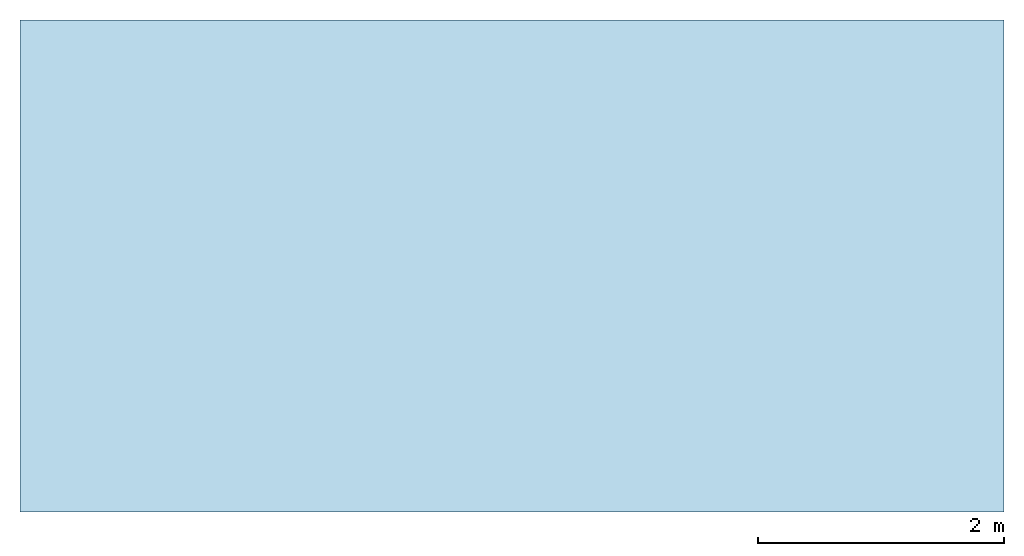
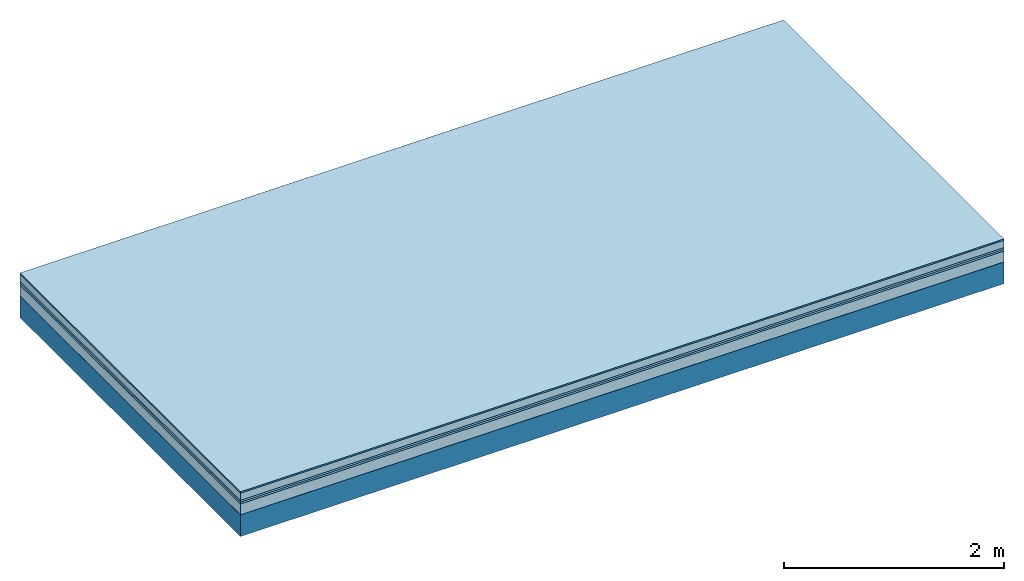
# One storey: 6 plates, 1 member, 1 element without a shape of its own.
"""IFC4 building model written with IfcOpenShell, lengths in metres."""

from ifc_helpers import new_model, si_unit, derived_unit, direction, frame, frame_2d, origin, origin_with_axes, place, context, project, spatial, rectangle, extrude, material, layer, layer_set, type_object, element, aggregate, save


model = new_model("IFC4")

# Units and contexts
plan_context = context("Plan", 3, precision=1e-05, world=origin(), true_north=direction((0.0, 1.0)))
model_context = context("Model", 3, precision=1e-05, world=origin(), true_north=direction((0.0, 1.0)))
ifc_project = project(units=[si_unit("LENGTHUNIT", "METRE"), derived_unit("SOUNDPRESSUREUNIT", [(si_unit("PRESSUREUNIT", "PASCAL", prefix="MICRO"), 0)]), si_unit("ENERGYUNIT", "JOULE", prefix="MEGA"), si_unit("MASSUNIT", "GRAM", prefix="KILO"), derived_unit("THERMALTRANSMITTANCEUNIT", [(si_unit("POWERUNIT", "WATT"), 1), (si_unit("AREAUNIT", "SQUARE_METRE"), -1), (si_unit("THERMODYNAMICTEMPERATUREUNIT", "KELVIN"), -1)]), derived_unit("AREADENSITYUNIT", [(si_unit("MASSUNIT", "GRAM", prefix="KILO"), 1), (si_unit("AREAUNIT", "SQUARE_METRE"), -1)]), derived_unit("USERDEFINED", [(si_unit("ENERGYUNIT", "JOULE", prefix="MEGA"), 1), (si_unit("AREAUNIT", "SQUARE_METRE"), -1)])], contexts=[plan_context, model_context])

# Site, building, storey
site = spatial("IfcSite", under=ifc_project)
building_placement = place(None, origin())
building = spatial("IfcBuilding", under=site, at=building_placement)
storey_placement = place(building_placement, origin())
storey = spatial("IfcBuildingStorey", under=building, at=storey_placement)

# Slab, member, plates
ifc_material_1 = material(Category="11.013")
ifc_layer_1 = layer(ifc_material_1, 0.015, Name="Flooring")
ifc_material_2 = material(Name="Cement screed", Category="04.006")
ifc_layer_2 = layer(ifc_material_2, 0.08, Name="On-material")
ifc_material_3 = material(Name="Wood fiber generic product", Category="10.009")
ifc_layer_3 = layer(ifc_material_3, 0.02, Name="Impact sound insulation")
ifc_material_4 = material()
ifc_layer_4 = layer(ifc_material_4, 0.02, Name="Additional insulation")
ifc_material_5 = material(Category="03.011")
ifc_layer_5 = layer(ifc_material_5, 0.12, Name="on Supporting structure")
ifc_material_6 = material(Name="protection", Category="09.007")
ifc_layer_6 = layer(ifc_material_6, 0.0005, Name="Sub-floor")
ifc_material_7 = material(Name="no composite action")
ifc_layer_7 = layer(ifc_material_7, 0.0, Name="Bond")
ifc_layer_8 = layer(None, 0.24, Name="Supporting structure")
ifc_layer_set = layer_set([ifc_layer_1, ifc_layer_2, ifc_layer_3, ifc_layer_4, ifc_layer_5, ifc_layer_6, ifc_layer_7, ifc_layer_8])
slab_type = type_object("IfcSlabType", Name="A2084", PredefinedType="NOTDEFINED", material=ifc_layer_set)
slab_placement = place(None, frame((0.0, 0.0, 0.0), z_axis=(0.0, 0.0, -1.0), x_axis=(1.0, 0.0, 0.0)))
slab = element("IfcSlab", 1, at=slab_placement, inside=storey, type_object=slab_type, material=ifc_layer_set, Name="Slab #1")
ifc_material_8 = material(Name="Solid timber panel")
member_placement = place(slab_placement, origin())
member = element("IfcMember", 2, at=member_placement, material=ifc_material_8, Name="Supporting structure", context=plan_context, shape_type="SweptSolid", body=[
    extrude(rectangle(XDim=1.0, YDim=0.24, at=frame_2d((0.5, 0.12), x_axis=(1.0, 0.0))), frame((0.0, 4.0, 0.2555), z_axis=(0.0, -1.0, 0.0), x_axis=(1.0, 0.0, 0.0)), (0.0, 0.0, 1.0), 4.0),
    extrude(rectangle(XDim=1.0, YDim=0.24, at=frame_2d((0.5, 0.12), x_axis=(1.0, 0.0))), frame((1.0, 4.0, 0.2555), z_axis=(0.0, -1.0, 0.0), x_axis=(1.0, 0.0, 0.0)), (0.0, 0.0, 1.0), 4.0),
    extrude(rectangle(XDim=1.0, YDim=0.24, at=frame_2d((0.5, 0.12), x_axis=(1.0, 0.0))), frame((2.0, 4.0, 0.2555), z_axis=(0.0, -1.0, 0.0), x_axis=(1.0, 0.0, 0.0)), (0.0, 0.0, 1.0), 4.0),
    extrude(rectangle(XDim=1.0, YDim=0.24, at=frame_2d((0.5, 0.12), x_axis=(1.0, 0.0))), frame((3.0, 4.0, 0.2555), z_axis=(0.0, -1.0, 0.0), x_axis=(1.0, 0.0, 0.0)), (0.0, 0.0, 1.0), 4.0),
    extrude(rectangle(XDim=1.0, YDim=0.24, at=frame_2d((0.5, 0.12), x_axis=(1.0, 0.0))), frame((4.0, 4.0, 0.2555), z_axis=(0.0, -1.0, 0.0), x_axis=(1.0, 0.0, 0.0)), (0.0, 0.0, 1.0), 4.0),
    extrude(rectangle(XDim=1.0, YDim=0.24, at=frame_2d((0.5, 0.12), x_axis=(1.0, 0.0))), frame((5.0, 4.0, 0.2555), z_axis=(0.0, -1.0, 0.0), x_axis=(1.0, 0.0, 0.0)), (0.0, 0.0, 1.0), 4.0),
    extrude(rectangle(XDim=1.0, YDim=0.24, at=frame_2d((0.5, 0.12), x_axis=(1.0, 0.0))), frame((6.0, 4.0, 0.2555), z_axis=(0.0, -1.0, 0.0), x_axis=(1.0, 0.0, 0.0)), (0.0, 0.0, 1.0), 4.0),
    extrude(rectangle(XDim=1.0, YDim=0.24, at=frame_2d((0.5, 0.12), x_axis=(1.0, 0.0))), frame((7.0, 4.0, 0.2555), z_axis=(0.0, -1.0, 0.0), x_axis=(1.0, 0.0, 0.0)), (0.0, 0.0, 1.0), 4.0),
])
plate_1_placement = place(slab_placement, origin())
plate_1 = element("IfcPlate", 3, at=plate_1_placement, material=ifc_material_1, Name="Flooring", context=plan_context, shape_type="SweptSolid", body=[
    extrude(rectangle(XDim=8.0, YDim=4.0, at=frame_2d((4.0, 2.0), x_axis=(1.0, 0.0))), origin_with_axes(), (0.0, 0.0, 1.0), 0.015),
])
plate_2_placement = place(slab_placement, origin())
plate_2 = element("IfcPlate", 4, at=plate_2_placement, material=ifc_material_2, Name="On-material", context=plan_context, shape_type="SweptSolid", body=[
    extrude(rectangle(XDim=8.0, YDim=4.0, at=frame_2d((4.0, 2.0), x_axis=(1.0, 0.0))), frame((0.0, 0.0, 0.015), z_axis=(0.0, 0.0, 1.0), x_axis=(1.0, 0.0, 0.0)), (0.0, 0.0, 1.0), 0.08),
])
plate_3_placement = place(slab_placement, origin())
plate_3 = element("IfcPlate", 5, at=plate_3_placement, material=ifc_material_3, Name="Impact sound insulation", context=plan_context, shape_type="SweptSolid", body=[
    extrude(rectangle(XDim=8.0, YDim=4.0, at=frame_2d((4.0, 2.0), x_axis=(1.0, 0.0))), frame((0.0, 0.0, 0.095), z_axis=(0.0, 0.0, 1.0), x_axis=(1.0, 0.0, 0.0)), (0.0, 0.0, 1.0), 0.02),
])
plate_4_placement = place(slab_placement, origin())
plate_4 = element("IfcPlate", 6, at=plate_4_placement, material=ifc_material_4, Name="Additional insulation", context=plan_context, shape_type="SweptSolid", body=[
    extrude(rectangle(XDim=8.0, YDim=4.0, at=frame_2d((4.0, 2.0), x_axis=(1.0, 0.0))), frame((0.0, 0.0, 0.115), z_axis=(0.0, 0.0, 1.0), x_axis=(1.0, 0.0, 0.0)), (0.0, 0.0, 1.0), 0.02),
])
plate_5_placement = place(slab_placement, origin())
plate_5 = element("IfcPlate", 7, at=plate_5_placement, material=ifc_material_5, Name="on Supporting structure", context=plan_context, shape_type="SweptSolid", body=[
    extrude(rectangle(XDim=8.0, YDim=4.0, at=frame_2d((4.0, 2.0), x_axis=(1.0, 0.0))), frame((0.0, 0.0, 0.135), z_axis=(0.0, 0.0, 1.0), x_axis=(1.0, 0.0, 0.0)), (0.0, 0.0, 1.0), 0.12),
])
plate_6_placement = place(slab_placement, origin())
plate_6 = element("IfcPlate", 8, at=plate_6_placement, material=ifc_material_6, Name="Sub-floor", context=plan_context, shape_type="SweptSolid", body=[
    extrude(rectangle(XDim=8.0, YDim=4.0, at=frame_2d((4.0, 2.0), x_axis=(1.0, 0.0))), frame((0.0, 0.0, 0.255), z_axis=(0.0, 0.0, 1.0), x_axis=(1.0, 0.0, 0.0)), (0.0, 0.0, 1.0), 0.0005),
])
aggregate(slab, [plate_1, plate_2, plate_3, plate_4, plate_5, plate_6, member])

save(model, "model.ifc")
